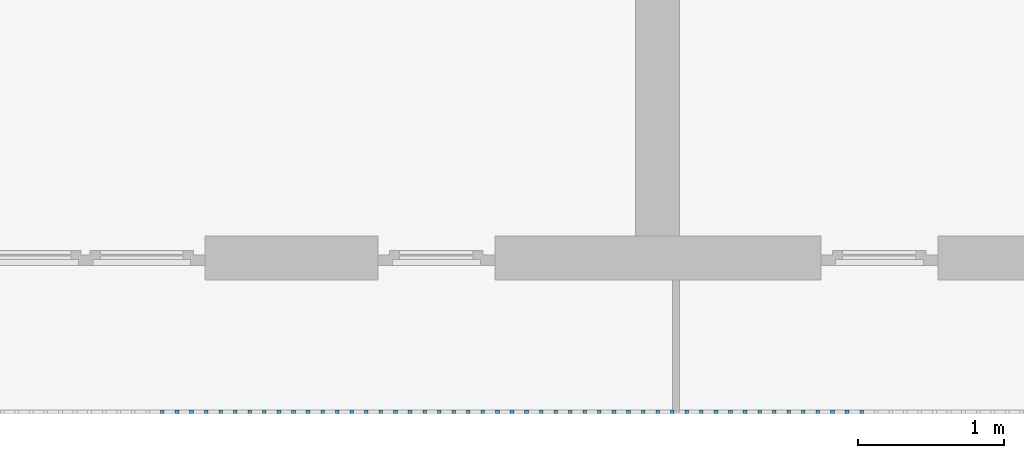
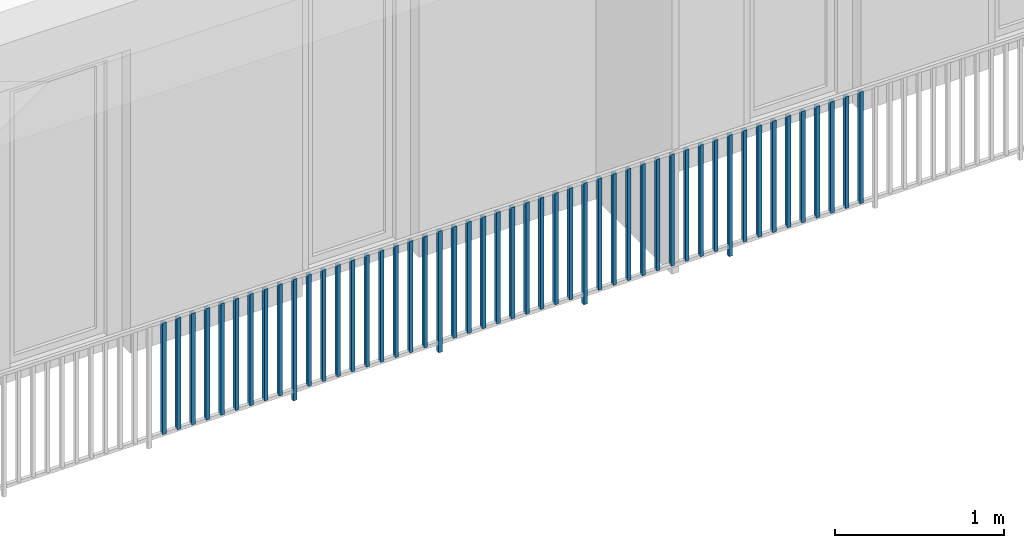
# One storey, part 29 of 48: 49 building element parts, 1 element without a shape of its own.
"""IFC4 building model written with IfcOpenShell, lengths in metres."""

from ifc_helpers import new_model, entity, si_unit, converted_unit, derived_unit, direction, frame, origin_with_axes, place, context, subcontext, project, spatial, polygons, material, type_object, element, aggregate, save


model = new_model("IFC4")

# Units and contexts
model_context = context("Model", 3, precision=1e-05, world=origin_with_axes(), true_north=direction((0.0, 1.0)))
body_context = subcontext(model_context, "Body", "Model", "MODEL_VIEW")
ifc_project = project(units=[si_unit("LENGTHUNIT", "METRE"), si_unit("AREAUNIT", "SQUARE_METRE"), si_unit("VOLUMEUNIT", "CUBIC_METRE"), converted_unit("PLANEANGLEUNIT", "DEGREE", entity("IfcPlaneAngleMeasure", 0.0174532925199), si_unit("PLANEANGLEUNIT", "RADIAN"), dimensions=[0, 0, 0, 0, 0, 0, 0]), converted_unit("TIMEUNIT", "Year", entity("IfcTimeMeasure", 31556926.0), si_unit("TIMEUNIT", "SECOND"), dimensions=[0, 0, 1, 0, 0, 0, 0]), si_unit("MASSUNIT", "GRAM", prefix="KILO"), si_unit("THERMODYNAMICTEMPERATUREUNIT", "DEGREE_CELSIUS"), si_unit("LUMINOUSINTENSITYUNIT", "LUMEN"), si_unit("ENERGYUNIT", "JOULE", prefix="MEGA"), derived_unit("THERMALCONDUCTANCEUNIT", [(si_unit("POWERUNIT", "WATT"), 1), (si_unit("LENGTHUNIT", "METRE"), -1), (si_unit("THERMODYNAMICTEMPERATUREUNIT", "KELVIN"), -1)]), derived_unit("SPECIFICHEATCAPACITYUNIT", [(si_unit("ENERGYUNIT", "JOULE"), 1), (si_unit("MASSUNIT", "GRAM", prefix="KILO"), -1), (si_unit("THERMODYNAMICTEMPERATUREUNIT", "KELVIN"), -1)]), derived_unit("MASSDENSITYUNIT", [(si_unit("MASSUNIT", "GRAM", prefix="KILO"), 1), (si_unit("VOLUMEUNIT", "CUBIC_METRE"), -1)])], contexts=[model_context])

# Site, building, storey
site_placement = place(None, origin_with_axes())
site = spatial("IfcSite", under=ifc_project, at=site_placement, CompositionType="ELEMENT")
building_placement = place(site_placement, origin_with_axes())
building = spatial("IfcBuilding", under=site, at=building_placement, CompositionType="ELEMENT")
storey_placement = place(building_placement, frame((0.0, 0.0, 3.4), z_axis=(0.0, 0.0, 1.0), x_axis=(1.0, 0.0, 0.0)))
storey = spatial("IfcBuildingStorey", under=building, at=storey_placement, Name="1. Geschoss", CompositionType="ELEMENT", Elevation=3.4)

# Railing, building element parts
railing_type = type_object("IfcRailingType", PredefinedType="NOTDEFINED")
railing_placement = place(storey_placement, frame((10.2378006196, 9.82118776896, 0.0), z_axis=(0.0, 0.0, 1.0), x_axis=(1.0, 0.0, 0.0)))
railing = element("IfcRailing", 1, at=railing_placement, inside=storey, type_object=railing_type, PredefinedType="NOTDEFINED")
ifc_material = material()
building_element_part_1_placement = place(railing_placement, origin_with_axes())
building_element_part_1 = element("IfcBuildingElementPart", 2, at=building_element_part_1_placement, material=ifc_material, PredefinedType="NOTDEFINED", context=body_context, shape_type="Tessellation", body=[
    polygons([(-14.8097608696, -20.6625, 0.07), (-14.8097608696, -20.6375, 0.07), (-14.8097608696, -20.6375, 0.8775), (-14.8097608696, -20.6625, 0.8775), (-14.8347608696, -20.6625, 0.07), (-14.8347608696, -20.6375, 0.07), (-14.8347608696, -20.6375, 0.8775), (-14.8347608696, -20.6625, 0.8775)], [[[1, 2, 3, 4]], [[1, 5, 6, 2]], [[2, 6, 7, 3]], [[4, 3, 7, 8]], [[5, 1, 4, 8]], [[6, 5, 8, 7]]], closed=True),
])
building_element_part_2_placement = place(railing_placement, origin_with_axes())
building_element_part_2 = element("IfcBuildingElementPart", 3, at=building_element_part_2_placement, material=ifc_material, PredefinedType="NOTDEFINED", context=body_context, shape_type="Tessellation", body=[
    polygons([(-14.7102826087, -20.6625, 0.07), (-14.7102826087, -20.6375, 0.07), (-14.7102826087, -20.6375, 0.8775), (-14.7102826087, -20.6625, 0.8775), (-14.7352826087, -20.6625, 0.07), (-14.7352826087, -20.6375, 0.07), (-14.7352826087, -20.6375, 0.8775), (-14.7352826087, -20.6625, 0.8775)], [[[1, 2, 3, 4]], [[1, 5, 6, 2]], [[2, 6, 7, 3]], [[4, 3, 7, 8]], [[5, 1, 4, 8]], [[6, 5, 8, 7]]], closed=True),
])
building_element_part_3_placement = place(railing_placement, origin_with_axes())
building_element_part_3 = element("IfcBuildingElementPart", 4, at=building_element_part_3_placement, material=ifc_material, PredefinedType="NOTDEFINED", context=body_context, shape_type="Tessellation", body=[
    polygons([(-14.6108043478, -20.6625, 0.07), (-14.6108043478, -20.6375, 0.07), (-14.6108043478, -20.6375, 0.8775), (-14.6108043478, -20.6625, 0.8775), (-14.6358043478, -20.6625, 0.07), (-14.6358043478, -20.6375, 0.07), (-14.6358043478, -20.6375, 0.8775), (-14.6358043478, -20.6625, 0.8775)], [[[1, 2, 3, 4]], [[1, 5, 6, 2]], [[2, 6, 7, 3]], [[4, 3, 7, 8]], [[5, 1, 4, 8]], [[6, 5, 8, 7]]], closed=True),
])
building_element_part_4_placement = place(railing_placement, origin_with_axes())
building_element_part_4 = element("IfcBuildingElementPart", 5, at=building_element_part_4_placement, material=ifc_material, PredefinedType="NOTDEFINED", context=body_context, shape_type="Tessellation", body=[
    polygons([(-14.511326087, -20.6625, 0.07), (-14.511326087, -20.6375, 0.07), (-14.511326087, -20.6375, 0.8775), (-14.511326087, -20.6625, 0.8775), (-14.536326087, -20.6625, 0.07), (-14.536326087, -20.6375, 0.07), (-14.536326087, -20.6375, 0.8775), (-14.536326087, -20.6625, 0.8775)], [[[1, 2, 3, 4]], [[1, 5, 6, 2]], [[2, 6, 7, 3]], [[4, 3, 7, 8]], [[5, 1, 4, 8]], [[6, 5, 8, 7]]], closed=True),
])
building_element_part_5_placement = place(railing_placement, origin_with_axes())
building_element_part_5 = element("IfcBuildingElementPart", 6, at=building_element_part_5_placement, material=ifc_material, PredefinedType="NOTDEFINED", context=body_context, shape_type="Tessellation", body=[
    polygons([(-14.4118478261, -20.6625, 0.07), (-14.4118478261, -20.6375, 0.07), (-14.4118478261, -20.6375, 0.8775), (-14.4118478261, -20.6625, 0.8775), (-14.4368478261, -20.6625, 0.07), (-14.4368478261, -20.6375, 0.07), (-14.4368478261, -20.6375, 0.8775), (-14.4368478261, -20.6625, 0.8775)], [[[1, 2, 3, 4]], [[1, 5, 6, 2]], [[2, 6, 7, 3]], [[4, 3, 7, 8]], [[5, 1, 4, 8]], [[6, 5, 8, 7]]], closed=True),
])
building_element_part_6_placement = place(railing_placement, origin_with_axes())
building_element_part_6 = element("IfcBuildingElementPart", 7, at=building_element_part_6_placement, material=ifc_material, PredefinedType="NOTDEFINED", context=body_context, shape_type="Tessellation", body=[
    polygons([(-14.3123695652, -20.6625, 0.07), (-14.3123695652, -20.6375, 0.07), (-14.3123695652, -20.6375, 0.8775), (-14.3123695652, -20.6625, 0.8775), (-14.3373695652, -20.6625, 0.07), (-14.3373695652, -20.6375, 0.07), (-14.3373695652, -20.6375, 0.8775), (-14.3373695652, -20.6625, 0.8775)], [[[1, 2, 3, 4]], [[1, 5, 6, 2]], [[2, 6, 7, 3]], [[4, 3, 7, 8]], [[5, 1, 4, 8]], [[6, 5, 8, 7]]], closed=True),
])
building_element_part_7_placement = place(railing_placement, origin_with_axes())
building_element_part_7 = element("IfcBuildingElementPart", 8, at=building_element_part_7_placement, material=ifc_material, PredefinedType="NOTDEFINED", context=body_context, shape_type="Tessellation", body=[
    polygons([(-14.2128913043, -20.6625, 0.07), (-14.2128913043, -20.6375, 0.07), (-14.2128913043, -20.6375, 0.8775), (-14.2128913043, -20.6625, 0.8775), (-14.2378913043, -20.6625, 0.07), (-14.2378913043, -20.6375, 0.07), (-14.2378913043, -20.6375, 0.8775), (-14.2378913043, -20.6625, 0.8775)], [[[1, 2, 3, 4]], [[1, 5, 6, 2]], [[2, 6, 7, 3]], [[4, 3, 7, 8]], [[5, 1, 4, 8]], [[6, 5, 8, 7]]], closed=True),
])
building_element_part_8_placement = place(railing_placement, origin_with_axes())
building_element_part_8 = element("IfcBuildingElementPart", 9, at=building_element_part_8_placement, material=ifc_material, PredefinedType="NOTDEFINED", context=body_context, shape_type="Tessellation", body=[
    polygons([(-14.1134130435, -20.6625, 0.07), (-14.1134130435, -20.6375, 0.07), (-14.1134130435, -20.6375, 0.8775), (-14.1134130435, -20.6625, 0.8775), (-14.1384130435, -20.6625, 0.07), (-14.1384130435, -20.6375, 0.07), (-14.1384130435, -20.6375, 0.8775), (-14.1384130435, -20.6625, 0.8775)], [[[1, 2, 3, 4]], [[1, 5, 6, 2]], [[2, 6, 7, 3]], [[4, 3, 7, 8]], [[5, 1, 4, 8]], [[6, 5, 8, 7]]], closed=True),
])
building_element_part_9_placement = place(railing_placement, origin_with_axes())
building_element_part_9 = element("IfcBuildingElementPart", 10, at=building_element_part_9_placement, material=ifc_material, PredefinedType="NOTDEFINED", context=body_context, shape_type="Tessellation", body=[
    polygons([(-14.0139347826, -20.6625, 0.07), (-14.0139347826, -20.6375, 0.07), (-14.0139347826, -20.6375, 0.8775), (-14.0139347826, -20.6625, 0.8775), (-14.0389347826, -20.6625, 0.07), (-14.0389347826, -20.6375, 0.07), (-14.0389347826, -20.6375, 0.8775), (-14.0389347826, -20.6625, 0.8775)], [[[1, 2, 3, 4]], [[1, 5, 6, 2]], [[2, 6, 7, 3]], [[4, 3, 7, 8]], [[5, 1, 4, 8]], [[6, 5, 8, 7]]], closed=True),
])
building_element_part_10_placement = place(railing_placement, origin_with_axes())
building_element_part_10 = element("IfcBuildingElementPart", 11, at=building_element_part_10_placement, material=ifc_material, PredefinedType="NOTDEFINED", context=body_context, shape_type="Tessellation", body=[
    polygons([(-13.9144565217, -20.6625, 0.0), (-13.9144565217, -20.6375, 0.0), (-13.9144565217, -20.6375, 0.88), (-13.9144565217, -20.6625, 0.88), (-13.9394565217, -20.6625, 0.0), (-13.9394565217, -20.6375, 0.0), (-13.9394565217, -20.6375, 0.88), (-13.9394565217, -20.6625, 0.88)], [[[1, 2, 3, 4]], [[1, 5, 6, 2]], [[2, 6, 7, 3]], [[4, 3, 7, 8]], [[5, 1, 4, 8]], [[6, 5, 8, 7]]], closed=True),
])
building_element_part_11_placement = place(railing_placement, origin_with_axes())
building_element_part_11 = element("IfcBuildingElementPart", 12, at=building_element_part_11_placement, material=ifc_material, PredefinedType="NOTDEFINED", context=body_context, shape_type="Tessellation", body=[
    polygons([(-13.8149782609, -20.6625, 0.07), (-13.8149782609, -20.6375, 0.07), (-13.8149782609, -20.6375, 0.8775), (-13.8149782609, -20.6625, 0.8775), (-13.8399782609, -20.6625, 0.07), (-13.8399782609, -20.6375, 0.07), (-13.8399782609, -20.6375, 0.8775), (-13.8399782609, -20.6625, 0.8775)], [[[1, 2, 3, 4]], [[1, 5, 6, 2]], [[2, 6, 7, 3]], [[4, 3, 7, 8]], [[5, 1, 4, 8]], [[6, 5, 8, 7]]], closed=True),
])
building_element_part_12_placement = place(railing_placement, origin_with_axes())
building_element_part_12 = element("IfcBuildingElementPart", 13, at=building_element_part_12_placement, material=ifc_material, PredefinedType="NOTDEFINED", context=body_context, shape_type="Tessellation", body=[
    polygons([(-13.7155, -20.6625, 0.07), (-13.7155, -20.6375, 0.07), (-13.7155, -20.6375, 0.8775), (-13.7155, -20.6625, 0.8775), (-13.7405, -20.6625, 0.07), (-13.7405, -20.6375, 0.07), (-13.7405, -20.6375, 0.8775), (-13.7405, -20.6625, 0.8775)], [[[1, 2, 3, 4]], [[1, 5, 6, 2]], [[2, 6, 7, 3]], [[4, 3, 7, 8]], [[5, 1, 4, 8]], [[6, 5, 8, 7]]], closed=True),
])
building_element_part_13_placement = place(railing_placement, origin_with_axes())
building_element_part_13 = element("IfcBuildingElementPart", 14, at=building_element_part_13_placement, material=ifc_material, PredefinedType="NOTDEFINED", context=body_context, shape_type="Tessellation", body=[
    polygons([(-13.6160217391, -20.6625, 0.07), (-13.6160217391, -20.6375, 0.07), (-13.6160217391, -20.6375, 0.8775), (-13.6160217391, -20.6625, 0.8775), (-13.6410217391, -20.6625, 0.07), (-13.6410217391, -20.6375, 0.07), (-13.6410217391, -20.6375, 0.8775), (-13.6410217391, -20.6625, 0.8775)], [[[1, 2, 3, 4]], [[1, 5, 6, 2]], [[2, 6, 7, 3]], [[4, 3, 7, 8]], [[5, 1, 4, 8]], [[6, 5, 8, 7]]], closed=True),
])
building_element_part_14_placement = place(railing_placement, origin_with_axes())
building_element_part_14 = element("IfcBuildingElementPart", 15, at=building_element_part_14_placement, material=ifc_material, PredefinedType="NOTDEFINED", context=body_context, shape_type="Tessellation", body=[
    polygons([(-13.5165434783, -20.6625, 0.07), (-13.5165434783, -20.6375, 0.07), (-13.5165434783, -20.6375, 0.8775), (-13.5165434783, -20.6625, 0.8775), (-13.5415434783, -20.6625, 0.07), (-13.5415434783, -20.6375, 0.07), (-13.5415434783, -20.6375, 0.8775), (-13.5415434783, -20.6625, 0.8775)], [[[1, 2, 3, 4]], [[1, 5, 6, 2]], [[2, 6, 7, 3]], [[4, 3, 7, 8]], [[5, 1, 4, 8]], [[6, 5, 8, 7]]], closed=True),
])
building_element_part_15_placement = place(railing_placement, origin_with_axes())
building_element_part_15 = element("IfcBuildingElementPart", 16, at=building_element_part_15_placement, material=ifc_material, PredefinedType="NOTDEFINED", context=body_context, shape_type="Tessellation", body=[
    polygons([(-13.4170652174, -20.6625, 0.07), (-13.4170652174, -20.6375, 0.07), (-13.4170652174, -20.6375, 0.8775), (-13.4170652174, -20.6625, 0.8775), (-13.4420652174, -20.6625, 0.07), (-13.4420652174, -20.6375, 0.07), (-13.4420652174, -20.6375, 0.8775), (-13.4420652174, -20.6625, 0.8775)], [[[1, 2, 3, 4]], [[1, 5, 6, 2]], [[2, 6, 7, 3]], [[4, 3, 7, 8]], [[5, 1, 4, 8]], [[6, 5, 8, 7]]], closed=True),
])
building_element_part_16_placement = place(railing_placement, origin_with_axes())
building_element_part_16 = element("IfcBuildingElementPart", 17, at=building_element_part_16_placement, material=ifc_material, PredefinedType="NOTDEFINED", context=body_context, shape_type="Tessellation", body=[
    polygons([(-13.3175869565, -20.6625, 0.07), (-13.3175869565, -20.6375, 0.07), (-13.3175869565, -20.6375, 0.8775), (-13.3175869565, -20.6625, 0.8775), (-13.3425869565, -20.6625, 0.07), (-13.3425869565, -20.6375, 0.07), (-13.3425869565, -20.6375, 0.8775), (-13.3425869565, -20.6625, 0.8775)], [[[1, 2, 3, 4]], [[1, 5, 6, 2]], [[2, 6, 7, 3]], [[4, 3, 7, 8]], [[5, 1, 4, 8]], [[6, 5, 8, 7]]], closed=True),
])
building_element_part_17_placement = place(railing_placement, origin_with_axes())
building_element_part_17 = element("IfcBuildingElementPart", 18, at=building_element_part_17_placement, material=ifc_material, PredefinedType="NOTDEFINED", context=body_context, shape_type="Tessellation", body=[
    polygons([(-13.2181086957, -20.6625, 0.07), (-13.2181086957, -20.6375, 0.07), (-13.2181086957, -20.6375, 0.8775), (-13.2181086957, -20.6625, 0.8775), (-13.2431086957, -20.6625, 0.07), (-13.2431086957, -20.6375, 0.07), (-13.2431086957, -20.6375, 0.8775), (-13.2431086957, -20.6625, 0.8775)], [[[1, 2, 3, 4]], [[1, 5, 6, 2]], [[2, 6, 7, 3]], [[4, 3, 7, 8]], [[5, 1, 4, 8]], [[6, 5, 8, 7]]], closed=True),
])
building_element_part_18_placement = place(railing_placement, origin_with_axes())
building_element_part_18 = element("IfcBuildingElementPart", 19, at=building_element_part_18_placement, material=ifc_material, PredefinedType="NOTDEFINED", context=body_context, shape_type="Tessellation", body=[
    polygons([(-13.1186304348, -20.6625, 0.07), (-13.1186304348, -20.6375, 0.07), (-13.1186304348, -20.6375, 0.8775), (-13.1186304348, -20.6625, 0.8775), (-13.1436304348, -20.6625, 0.07), (-13.1436304348, -20.6375, 0.07), (-13.1436304348, -20.6375, 0.8775), (-13.1436304348, -20.6625, 0.8775)], [[[1, 2, 3, 4]], [[1, 5, 6, 2]], [[2, 6, 7, 3]], [[4, 3, 7, 8]], [[5, 1, 4, 8]], [[6, 5, 8, 7]]], closed=True),
])
building_element_part_19_placement = place(railing_placement, origin_with_axes())
building_element_part_19 = element("IfcBuildingElementPart", 20, at=building_element_part_19_placement, material=ifc_material, PredefinedType="NOTDEFINED", context=body_context, shape_type="Tessellation", body=[
    polygons([(-13.0191521739, -20.6625, 0.07), (-13.0191521739, -20.6375, 0.07), (-13.0191521739, -20.6375, 0.8775), (-13.0191521739, -20.6625, 0.8775), (-13.0441521739, -20.6625, 0.07), (-13.0441521739, -20.6375, 0.07), (-13.0441521739, -20.6375, 0.8775), (-13.0441521739, -20.6625, 0.8775)], [[[1, 2, 3, 4]], [[1, 5, 6, 2]], [[2, 6, 7, 3]], [[4, 3, 7, 8]], [[5, 1, 4, 8]], [[6, 5, 8, 7]]], closed=True),
])
building_element_part_20_placement = place(railing_placement, origin_with_axes())
building_element_part_20 = element("IfcBuildingElementPart", 21, at=building_element_part_20_placement, material=ifc_material, PredefinedType="NOTDEFINED", context=body_context, shape_type="Tessellation", body=[
    polygons([(-12.919673913, -20.6625, 0.0), (-12.919673913, -20.6375, 0.0), (-12.919673913, -20.6375, 0.88), (-12.919673913, -20.6625, 0.88), (-12.944673913, -20.6625, 0.0), (-12.944673913, -20.6375, 0.0), (-12.944673913, -20.6375, 0.88), (-12.944673913, -20.6625, 0.88)], [[[1, 2, 3, 4]], [[1, 5, 6, 2]], [[2, 6, 7, 3]], [[4, 3, 7, 8]], [[5, 1, 4, 8]], [[6, 5, 8, 7]]], closed=True),
])
building_element_part_21_placement = place(railing_placement, origin_with_axes())
building_element_part_21 = element("IfcBuildingElementPart", 22, at=building_element_part_21_placement, material=ifc_material, PredefinedType="NOTDEFINED", context=body_context, shape_type="Tessellation", body=[
    polygons([(-12.8201956522, -20.6625, 0.07), (-12.8201956522, -20.6375, 0.07), (-12.8201956522, -20.6375, 0.8775), (-12.8201956522, -20.6625, 0.8775), (-12.8451956522, -20.6625, 0.07), (-12.8451956522, -20.6375, 0.07), (-12.8451956522, -20.6375, 0.8775), (-12.8451956522, -20.6625, 0.8775)], [[[1, 2, 3, 4]], [[1, 5, 6, 2]], [[2, 6, 7, 3]], [[4, 3, 7, 8]], [[5, 1, 4, 8]], [[6, 5, 8, 7]]], closed=True),
])
building_element_part_22_placement = place(railing_placement, origin_with_axes())
building_element_part_22 = element("IfcBuildingElementPart", 23, at=building_element_part_22_placement, material=ifc_material, PredefinedType="NOTDEFINED", context=body_context, shape_type="Tessellation", body=[
    polygons([(-12.7207173913, -20.6625, 0.07), (-12.7207173913, -20.6375, 0.07), (-12.7207173913, -20.6375, 0.8775), (-12.7207173913, -20.6625, 0.8775), (-12.7457173913, -20.6625, 0.07), (-12.7457173913, -20.6375, 0.07), (-12.7457173913, -20.6375, 0.8775), (-12.7457173913, -20.6625, 0.8775)], [[[1, 2, 3, 4]], [[1, 5, 6, 2]], [[2, 6, 7, 3]], [[4, 3, 7, 8]], [[5, 1, 4, 8]], [[6, 5, 8, 7]]], closed=True),
])
building_element_part_23_placement = place(railing_placement, origin_with_axes())
building_element_part_23 = element("IfcBuildingElementPart", 24, at=building_element_part_23_placement, material=ifc_material, PredefinedType="NOTDEFINED", context=body_context, shape_type="Tessellation", body=[
    polygons([(-12.6212391304, -20.6625, 0.07), (-12.6212391304, -20.6375, 0.07), (-12.6212391304, -20.6375, 0.8775), (-12.6212391304, -20.6625, 0.8775), (-12.6462391304, -20.6625, 0.07), (-12.6462391304, -20.6375, 0.07), (-12.6462391304, -20.6375, 0.8775), (-12.6462391304, -20.6625, 0.8775)], [[[1, 2, 3, 4]], [[1, 5, 6, 2]], [[2, 6, 7, 3]], [[4, 3, 7, 8]], [[5, 1, 4, 8]], [[6, 5, 8, 7]]], closed=True),
])
building_element_part_24_placement = place(railing_placement, origin_with_axes())
building_element_part_24 = element("IfcBuildingElementPart", 25, at=building_element_part_24_placement, material=ifc_material, PredefinedType="NOTDEFINED", context=body_context, shape_type="Tessellation", body=[
    polygons([(-12.5217608696, -20.6625, 0.07), (-12.5217608696, -20.6375, 0.07), (-12.5217608696, -20.6375, 0.8775), (-12.5217608696, -20.6625, 0.8775), (-12.5467608696, -20.6625, 0.07), (-12.5467608696, -20.6375, 0.07), (-12.5467608696, -20.6375, 0.8775), (-12.5467608696, -20.6625, 0.8775)], [[[1, 2, 3, 4]], [[1, 5, 6, 2]], [[2, 6, 7, 3]], [[4, 3, 7, 8]], [[5, 1, 4, 8]], [[6, 5, 8, 7]]], closed=True),
])
building_element_part_25_placement = place(railing_placement, origin_with_axes())
building_element_part_25 = element("IfcBuildingElementPart", 26, at=building_element_part_25_placement, material=ifc_material, PredefinedType="NOTDEFINED", context=body_context, shape_type="Tessellation", body=[
    polygons([(-12.4222826087, -20.6625, 0.07), (-12.4222826087, -20.6375, 0.07), (-12.4222826087, -20.6375, 0.8775), (-12.4222826087, -20.6625, 0.8775), (-12.4472826087, -20.6625, 0.07), (-12.4472826087, -20.6375, 0.07), (-12.4472826087, -20.6375, 0.8775), (-12.4472826087, -20.6625, 0.8775)], [[[1, 2, 3, 4]], [[1, 5, 6, 2]], [[2, 6, 7, 3]], [[4, 3, 7, 8]], [[5, 1, 4, 8]], [[6, 5, 8, 7]]], closed=True),
])
building_element_part_26_placement = place(railing_placement, origin_with_axes())
building_element_part_26 = element("IfcBuildingElementPart", 27, at=building_element_part_26_placement, material=ifc_material, PredefinedType="NOTDEFINED", context=body_context, shape_type="Tessellation", body=[
    polygons([(-12.3228043478, -20.6625, 0.07), (-12.3228043478, -20.6375, 0.07), (-12.3228043478, -20.6375, 0.8775), (-12.3228043478, -20.6625, 0.8775), (-12.3478043478, -20.6625, 0.07), (-12.3478043478, -20.6375, 0.07), (-12.3478043478, -20.6375, 0.8775), (-12.3478043478, -20.6625, 0.8775)], [[[1, 2, 3, 4]], [[1, 5, 6, 2]], [[2, 6, 7, 3]], [[4, 3, 7, 8]], [[5, 1, 4, 8]], [[6, 5, 8, 7]]], closed=True),
])
building_element_part_27_placement = place(railing_placement, origin_with_axes())
building_element_part_27 = element("IfcBuildingElementPart", 28, at=building_element_part_27_placement, material=ifc_material, PredefinedType="NOTDEFINED", context=body_context, shape_type="Tessellation", body=[
    polygons([(-12.223326087, -20.6625, 0.07), (-12.223326087, -20.6375, 0.07), (-12.223326087, -20.6375, 0.8775), (-12.223326087, -20.6625, 0.8775), (-12.248326087, -20.6625, 0.07), (-12.248326087, -20.6375, 0.07), (-12.248326087, -20.6375, 0.8775), (-12.248326087, -20.6625, 0.8775)], [[[1, 2, 3, 4]], [[1, 5, 6, 2]], [[2, 6, 7, 3]], [[4, 3, 7, 8]], [[5, 1, 4, 8]], [[6, 5, 8, 7]]], closed=True),
])
building_element_part_28_placement = place(railing_placement, origin_with_axes())
building_element_part_28 = element("IfcBuildingElementPart", 29, at=building_element_part_28_placement, material=ifc_material, PredefinedType="NOTDEFINED", context=body_context, shape_type="Tessellation", body=[
    polygons([(-12.1238478261, -20.6625, 0.07), (-12.1238478261, -20.6375, 0.07), (-12.1238478261, -20.6375, 0.8775), (-12.1238478261, -20.6625, 0.8775), (-12.1488478261, -20.6625, 0.07), (-12.1488478261, -20.6375, 0.07), (-12.1488478261, -20.6375, 0.8775), (-12.1488478261, -20.6625, 0.8775)], [[[1, 2, 3, 4]], [[1, 5, 6, 2]], [[2, 6, 7, 3]], [[4, 3, 7, 8]], [[5, 1, 4, 8]], [[6, 5, 8, 7]]], closed=True),
])
building_element_part_29_placement = place(railing_placement, origin_with_axes())
building_element_part_29 = element("IfcBuildingElementPart", 30, at=building_element_part_29_placement, material=ifc_material, PredefinedType="NOTDEFINED", context=body_context, shape_type="Tessellation", body=[
    polygons([(-12.0243695652, -20.6625, 0.07), (-12.0243695652, -20.6375, 0.07), (-12.0243695652, -20.6375, 0.8775), (-12.0243695652, -20.6625, 0.8775), (-12.0493695652, -20.6625, 0.07), (-12.0493695652, -20.6375, 0.07), (-12.0493695652, -20.6375, 0.8775), (-12.0493695652, -20.6625, 0.8775)], [[[1, 2, 3, 4]], [[1, 5, 6, 2]], [[2, 6, 7, 3]], [[4, 3, 7, 8]], [[5, 1, 4, 8]], [[6, 5, 8, 7]]], closed=True),
])
building_element_part_30_placement = place(railing_placement, origin_with_axes())
building_element_part_30 = element("IfcBuildingElementPart", 31, at=building_element_part_30_placement, material=ifc_material, PredefinedType="NOTDEFINED", context=body_context, shape_type="Tessellation", body=[
    polygons([(-11.9248913043, -20.6625, 0.0), (-11.9248913043, -20.6375, 0.0), (-11.9248913043, -20.6375, 0.88), (-11.9248913043, -20.6625, 0.88), (-11.9498913043, -20.6625, 0.0), (-11.9498913043, -20.6375, 0.0), (-11.9498913043, -20.6375, 0.88), (-11.9498913043, -20.6625, 0.88)], [[[1, 2, 3, 4]], [[1, 5, 6, 2]], [[2, 6, 7, 3]], [[4, 3, 7, 8]], [[5, 1, 4, 8]], [[6, 5, 8, 7]]], closed=True),
])
building_element_part_31_placement = place(railing_placement, origin_with_axes())
building_element_part_31 = element("IfcBuildingElementPart", 32, at=building_element_part_31_placement, material=ifc_material, PredefinedType="NOTDEFINED", context=body_context, shape_type="Tessellation", body=[
    polygons([(-11.8254130435, -20.6625, 0.07), (-11.8254130435, -20.6375, 0.07), (-11.8254130435, -20.6375, 0.8775), (-11.8254130435, -20.6625, 0.8775), (-11.8504130435, -20.6625, 0.07), (-11.8504130435, -20.6375, 0.07), (-11.8504130435, -20.6375, 0.8775), (-11.8504130435, -20.6625, 0.8775)], [[[1, 2, 3, 4]], [[1, 5, 6, 2]], [[2, 6, 7, 3]], [[4, 3, 7, 8]], [[5, 1, 4, 8]], [[6, 5, 8, 7]]], closed=True),
])
building_element_part_32_placement = place(railing_placement, origin_with_axes())
building_element_part_32 = element("IfcBuildingElementPart", 33, at=building_element_part_32_placement, material=ifc_material, PredefinedType="NOTDEFINED", context=body_context, shape_type="Tessellation", body=[
    polygons([(-11.7259347826, -20.6625, 0.07), (-11.7259347826, -20.6375, 0.07), (-11.7259347826, -20.6375, 0.8775), (-11.7259347826, -20.6625, 0.8775), (-11.7509347826, -20.6625, 0.07), (-11.7509347826, -20.6375, 0.07), (-11.7509347826, -20.6375, 0.8775), (-11.7509347826, -20.6625, 0.8775)], [[[1, 2, 3, 4]], [[1, 5, 6, 2]], [[2, 6, 7, 3]], [[4, 3, 7, 8]], [[5, 1, 4, 8]], [[6, 5, 8, 7]]], closed=True),
])
building_element_part_33_placement = place(railing_placement, origin_with_axes())
building_element_part_33 = element("IfcBuildingElementPart", 34, at=building_element_part_33_placement, material=ifc_material, PredefinedType="NOTDEFINED", context=body_context, shape_type="Tessellation", body=[
    polygons([(-11.6264565217, -20.6625, 0.07), (-11.6264565217, -20.6375, 0.07), (-11.6264565217, -20.6375, 0.8775), (-11.6264565217, -20.6625, 0.8775), (-11.6514565217, -20.6625, 0.07), (-11.6514565217, -20.6375, 0.07), (-11.6514565217, -20.6375, 0.8775), (-11.6514565217, -20.6625, 0.8775)], [[[1, 2, 3, 4]], [[1, 5, 6, 2]], [[2, 6, 7, 3]], [[4, 3, 7, 8]], [[5, 1, 4, 8]], [[6, 5, 8, 7]]], closed=True),
])
building_element_part_34_placement = place(railing_placement, origin_with_axes())
building_element_part_34 = element("IfcBuildingElementPart", 35, at=building_element_part_34_placement, material=ifc_material, PredefinedType="NOTDEFINED", context=body_context, shape_type="Tessellation", body=[
    polygons([(-11.5269782609, -20.6625, 0.07), (-11.5269782609, -20.6375, 0.07), (-11.5269782609, -20.6375, 0.8775), (-11.5269782609, -20.6625, 0.8775), (-11.5519782609, -20.6625, 0.07), (-11.5519782609, -20.6375, 0.07), (-11.5519782609, -20.6375, 0.8775), (-11.5519782609, -20.6625, 0.8775)], [[[1, 2, 3, 4]], [[1, 5, 6, 2]], [[2, 6, 7, 3]], [[4, 3, 7, 8]], [[5, 1, 4, 8]], [[6, 5, 8, 7]]], closed=True),
])
building_element_part_35_placement = place(railing_placement, origin_with_axes())
building_element_part_35 = element("IfcBuildingElementPart", 36, at=building_element_part_35_placement, material=ifc_material, PredefinedType="NOTDEFINED", context=body_context, shape_type="Tessellation", body=[
    polygons([(-11.4275, -20.6625, 0.07), (-11.4275, -20.6375, 0.07), (-11.4275, -20.6375, 0.8775), (-11.4275, -20.6625, 0.8775), (-11.4525, -20.6625, 0.07), (-11.4525, -20.6375, 0.07), (-11.4525, -20.6375, 0.8775), (-11.4525, -20.6625, 0.8775)], [[[1, 2, 3, 4]], [[1, 5, 6, 2]], [[2, 6, 7, 3]], [[4, 3, 7, 8]], [[5, 1, 4, 8]], [[6, 5, 8, 7]]], closed=True),
])
building_element_part_36_placement = place(railing_placement, origin_with_axes())
building_element_part_36 = element("IfcBuildingElementPart", 37, at=building_element_part_36_placement, material=ifc_material, PredefinedType="NOTDEFINED", context=body_context, shape_type="Tessellation", body=[
    polygons([(-11.3280217391, -20.6625, 0.07), (-11.3280217391, -20.6375, 0.07), (-11.3280217391, -20.6375, 0.8775), (-11.3280217391, -20.6625, 0.8775), (-11.3530217391, -20.6625, 0.07), (-11.3530217391, -20.6375, 0.07), (-11.3530217391, -20.6375, 0.8775), (-11.3530217391, -20.6625, 0.8775)], [[[1, 2, 3, 4]], [[1, 5, 6, 2]], [[2, 6, 7, 3]], [[4, 3, 7, 8]], [[5, 1, 4, 8]], [[6, 5, 8, 7]]], closed=True),
])
building_element_part_37_placement = place(railing_placement, origin_with_axes())
building_element_part_37 = element("IfcBuildingElementPart", 38, at=building_element_part_37_placement, material=ifc_material, PredefinedType="NOTDEFINED", context=body_context, shape_type="Tessellation", body=[
    polygons([(-11.2285434783, -20.6625, 0.07), (-11.2285434783, -20.6375, 0.07), (-11.2285434783, -20.6375, 0.8775), (-11.2285434783, -20.6625, 0.8775), (-11.2535434783, -20.6625, 0.07), (-11.2535434783, -20.6375, 0.07), (-11.2535434783, -20.6375, 0.8775), (-11.2535434783, -20.6625, 0.8775)], [[[1, 2, 3, 4]], [[1, 5, 6, 2]], [[2, 6, 7, 3]], [[4, 3, 7, 8]], [[5, 1, 4, 8]], [[6, 5, 8, 7]]], closed=True),
])
building_element_part_38_placement = place(railing_placement, origin_with_axes())
building_element_part_38 = element("IfcBuildingElementPart", 39, at=building_element_part_38_placement, material=ifc_material, PredefinedType="NOTDEFINED", context=body_context, shape_type="Tessellation", body=[
    polygons([(-11.1290652174, -20.6625, 0.07), (-11.1290652174, -20.6375, 0.07), (-11.1290652174, -20.6375, 0.8775), (-11.1290652174, -20.6625, 0.8775), (-11.1540652174, -20.6625, 0.07), (-11.1540652174, -20.6375, 0.07), (-11.1540652174, -20.6375, 0.8775), (-11.1540652174, -20.6625, 0.8775)], [[[1, 2, 3, 4]], [[1, 5, 6, 2]], [[2, 6, 7, 3]], [[4, 3, 7, 8]], [[5, 1, 4, 8]], [[6, 5, 8, 7]]], closed=True),
])
building_element_part_39_placement = place(railing_placement, origin_with_axes())
building_element_part_39 = element("IfcBuildingElementPart", 40, at=building_element_part_39_placement, material=ifc_material, PredefinedType="NOTDEFINED", context=body_context, shape_type="Tessellation", body=[
    polygons([(-11.0295869565, -20.6625, 0.07), (-11.0295869565, -20.6375, 0.07), (-11.0295869565, -20.6375, 0.8775), (-11.0295869565, -20.6625, 0.8775), (-11.0545869565, -20.6625, 0.07), (-11.0545869565, -20.6375, 0.07), (-11.0545869565, -20.6375, 0.8775), (-11.0545869565, -20.6625, 0.8775)], [[[1, 2, 3, 4]], [[1, 5, 6, 2]], [[2, 6, 7, 3]], [[4, 3, 7, 8]], [[5, 1, 4, 8]], [[6, 5, 8, 7]]], closed=True),
])
building_element_part_40_placement = place(railing_placement, origin_with_axes())
building_element_part_40 = element("IfcBuildingElementPart", 41, at=building_element_part_40_placement, material=ifc_material, PredefinedType="NOTDEFINED", context=body_context, shape_type="Tessellation", body=[
    polygons([(-10.9301086957, -20.6625, 0.0), (-10.9301086957, -20.6375, 0.0), (-10.9301086957, -20.6375, 0.88), (-10.9301086957, -20.6625, 0.88), (-10.9551086957, -20.6625, 0.0), (-10.9551086957, -20.6375, 0.0), (-10.9551086957, -20.6375, 0.88), (-10.9551086957, -20.6625, 0.88)], [[[1, 2, 3, 4]], [[1, 5, 6, 2]], [[2, 6, 7, 3]], [[4, 3, 7, 8]], [[5, 1, 4, 8]], [[6, 5, 8, 7]]], closed=True),
])
building_element_part_41_placement = place(railing_placement, origin_with_axes())
building_element_part_41 = element("IfcBuildingElementPart", 42, at=building_element_part_41_placement, material=ifc_material, PredefinedType="NOTDEFINED", context=body_context, shape_type="Tessellation", body=[
    polygons([(-10.8306304348, -20.6625, 0.07), (-10.8306304348, -20.6375, 0.07), (-10.8306304348, -20.6375, 0.8775), (-10.8306304348, -20.6625, 0.8775), (-10.8556304348, -20.6625, 0.07), (-10.8556304348, -20.6375, 0.07), (-10.8556304348, -20.6375, 0.8775), (-10.8556304348, -20.6625, 0.8775)], [[[1, 2, 3, 4]], [[1, 5, 6, 2]], [[2, 6, 7, 3]], [[4, 3, 7, 8]], [[5, 1, 4, 8]], [[6, 5, 8, 7]]], closed=True),
])
building_element_part_42_placement = place(railing_placement, origin_with_axes())
building_element_part_42 = element("IfcBuildingElementPart", 43, at=building_element_part_42_placement, material=ifc_material, PredefinedType="NOTDEFINED", context=body_context, shape_type="Tessellation", body=[
    polygons([(-10.7311521739, -20.6625, 0.07), (-10.7311521739, -20.6375, 0.07), (-10.7311521739, -20.6375, 0.8775), (-10.7311521739, -20.6625, 0.8775), (-10.7561521739, -20.6625, 0.07), (-10.7561521739, -20.6375, 0.07), (-10.7561521739, -20.6375, 0.8775), (-10.7561521739, -20.6625, 0.8775)], [[[1, 2, 3, 4]], [[1, 5, 6, 2]], [[2, 6, 7, 3]], [[4, 3, 7, 8]], [[5, 1, 4, 8]], [[6, 5, 8, 7]]], closed=True),
])
building_element_part_43_placement = place(railing_placement, origin_with_axes())
building_element_part_43 = element("IfcBuildingElementPart", 44, at=building_element_part_43_placement, material=ifc_material, PredefinedType="NOTDEFINED", context=body_context, shape_type="Tessellation", body=[
    polygons([(-10.631673913, -20.6625, 0.07), (-10.631673913, -20.6375, 0.07), (-10.631673913, -20.6375, 0.8775), (-10.631673913, -20.6625, 0.8775), (-10.656673913, -20.6625, 0.07), (-10.656673913, -20.6375, 0.07), (-10.656673913, -20.6375, 0.8775), (-10.656673913, -20.6625, 0.8775)], [[[1, 2, 3, 4]], [[1, 5, 6, 2]], [[2, 6, 7, 3]], [[4, 3, 7, 8]], [[5, 1, 4, 8]], [[6, 5, 8, 7]]], closed=True),
])
building_element_part_44_placement = place(railing_placement, origin_with_axes())
building_element_part_44 = element("IfcBuildingElementPart", 45, at=building_element_part_44_placement, material=ifc_material, PredefinedType="NOTDEFINED", context=body_context, shape_type="Tessellation", body=[
    polygons([(-10.5321956522, -20.6625, 0.07), (-10.5321956522, -20.6375, 0.07), (-10.5321956522, -20.6375, 0.8775), (-10.5321956522, -20.6625, 0.8775), (-10.5571956522, -20.6625, 0.07), (-10.5571956522, -20.6375, 0.07), (-10.5571956522, -20.6375, 0.8775), (-10.5571956522, -20.6625, 0.8775)], [[[1, 2, 3, 4]], [[1, 5, 6, 2]], [[2, 6, 7, 3]], [[4, 3, 7, 8]], [[5, 1, 4, 8]], [[6, 5, 8, 7]]], closed=True),
])
building_element_part_45_placement = place(railing_placement, origin_with_axes())
building_element_part_45 = element("IfcBuildingElementPart", 46, at=building_element_part_45_placement, material=ifc_material, PredefinedType="NOTDEFINED", context=body_context, shape_type="Tessellation", body=[
    polygons([(-10.4327173913, -20.6625, 0.07), (-10.4327173913, -20.6375, 0.07), (-10.4327173913, -20.6375, 0.8775), (-10.4327173913, -20.6625, 0.8775), (-10.4577173913, -20.6625, 0.07), (-10.4577173913, -20.6375, 0.07), (-10.4577173913, -20.6375, 0.8775), (-10.4577173913, -20.6625, 0.8775)], [[[1, 2, 3, 4]], [[1, 5, 6, 2]], [[2, 6, 7, 3]], [[4, 3, 7, 8]], [[5, 1, 4, 8]], [[6, 5, 8, 7]]], closed=True),
])
building_element_part_46_placement = place(railing_placement, origin_with_axes())
building_element_part_46 = element("IfcBuildingElementPart", 47, at=building_element_part_46_placement, material=ifc_material, PredefinedType="NOTDEFINED", context=body_context, shape_type="Tessellation", body=[
    polygons([(-10.3332391304, -20.6625, 0.07), (-10.3332391304, -20.6375, 0.07), (-10.3332391304, -20.6375, 0.8775), (-10.3332391304, -20.6625, 0.8775), (-10.3582391304, -20.6625, 0.07), (-10.3582391304, -20.6375, 0.07), (-10.3582391304, -20.6375, 0.8775), (-10.3582391304, -20.6625, 0.8775)], [[[1, 2, 3, 4]], [[1, 5, 6, 2]], [[2, 6, 7, 3]], [[4, 3, 7, 8]], [[5, 1, 4, 8]], [[6, 5, 8, 7]]], closed=True),
])
building_element_part_47_placement = place(railing_placement, origin_with_axes())
building_element_part_47 = element("IfcBuildingElementPart", 48, at=building_element_part_47_placement, material=ifc_material, PredefinedType="NOTDEFINED", context=body_context, shape_type="Tessellation", body=[
    polygons([(-10.2337608696, -20.6625, 0.07), (-10.2337608696, -20.6375, 0.07), (-10.2337608696, -20.6375, 0.8775), (-10.2337608696, -20.6625, 0.8775), (-10.2587608696, -20.6625, 0.07), (-10.2587608696, -20.6375, 0.07), (-10.2587608696, -20.6375, 0.8775), (-10.2587608696, -20.6625, 0.8775)], [[[1, 2, 3, 4]], [[1, 5, 6, 2]], [[2, 6, 7, 3]], [[4, 3, 7, 8]], [[5, 1, 4, 8]], [[6, 5, 8, 7]]], closed=True),
])
building_element_part_48_placement = place(railing_placement, origin_with_axes())
building_element_part_48 = element("IfcBuildingElementPart", 49, at=building_element_part_48_placement, material=ifc_material, PredefinedType="NOTDEFINED", context=body_context, shape_type="Tessellation", body=[
    polygons([(-10.1342826087, -20.6625, 0.07), (-10.1342826087, -20.6375, 0.07), (-10.1342826087, -20.6375, 0.8775), (-10.1342826087, -20.6625, 0.8775), (-10.1592826087, -20.6625, 0.07), (-10.1592826087, -20.6375, 0.07), (-10.1592826087, -20.6375, 0.8775), (-10.1592826087, -20.6625, 0.8775)], [[[1, 2, 3, 4]], [[1, 5, 6, 2]], [[2, 6, 7, 3]], [[4, 3, 7, 8]], [[5, 1, 4, 8]], [[6, 5, 8, 7]]], closed=True),
])
building_element_part_49_placement = place(railing_placement, origin_with_axes())
building_element_part_49 = element("IfcBuildingElementPart", 50, at=building_element_part_49_placement, material=ifc_material, PredefinedType="NOTDEFINED", context=body_context, shape_type="Tessellation", body=[
    polygons([(-10.0348043478, -20.6625, 0.07), (-10.0348043478, -20.6375, 0.07), (-10.0348043478, -20.6375, 0.8775), (-10.0348043478, -20.6625, 0.8775), (-10.0598043478, -20.6625, 0.07), (-10.0598043478, -20.6375, 0.07), (-10.0598043478, -20.6375, 0.8775), (-10.0598043478, -20.6625, 0.8775)], [[[1, 2, 3, 4]], [[1, 5, 6, 2]], [[2, 6, 7, 3]], [[4, 3, 7, 8]], [[5, 1, 4, 8]], [[6, 5, 8, 7]]], closed=True),
])
aggregate(railing, [building_element_part_1, building_element_part_2, building_element_part_3, building_element_part_4, building_element_part_5, building_element_part_6, building_element_part_7, building_element_part_8, building_element_part_9, building_element_part_10, building_element_part_11, building_element_part_12, building_element_part_13, building_element_part_14, building_element_part_15, building_element_part_16, building_element_part_17, building_element_part_18, building_element_part_19, building_element_part_20, building_element_part_21, building_element_part_22, building_element_part_23, building_element_part_24, building_element_part_25, building_element_part_26, building_element_part_27, building_element_part_28, building_element_part_29, building_element_part_30, building_element_part_31, building_element_part_32, building_element_part_33, building_element_part_34, building_element_part_35, building_element_part_36, building_element_part_37, building_element_part_38, building_element_part_39, building_element_part_40, building_element_part_41, building_element_part_42, building_element_part_43, building_element_part_44, building_element_part_45, building_element_part_46, building_element_part_47, building_element_part_48, building_element_part_49])

save(model, "model.ifc")
